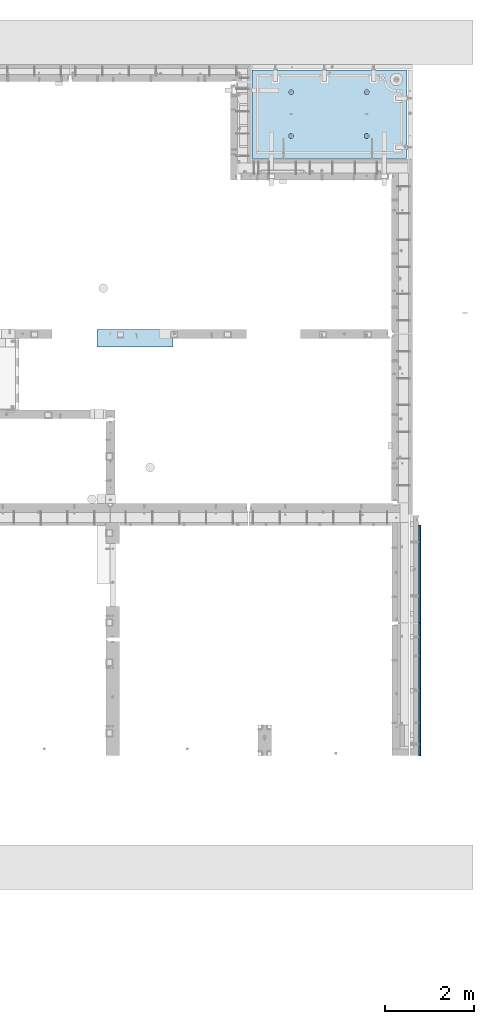
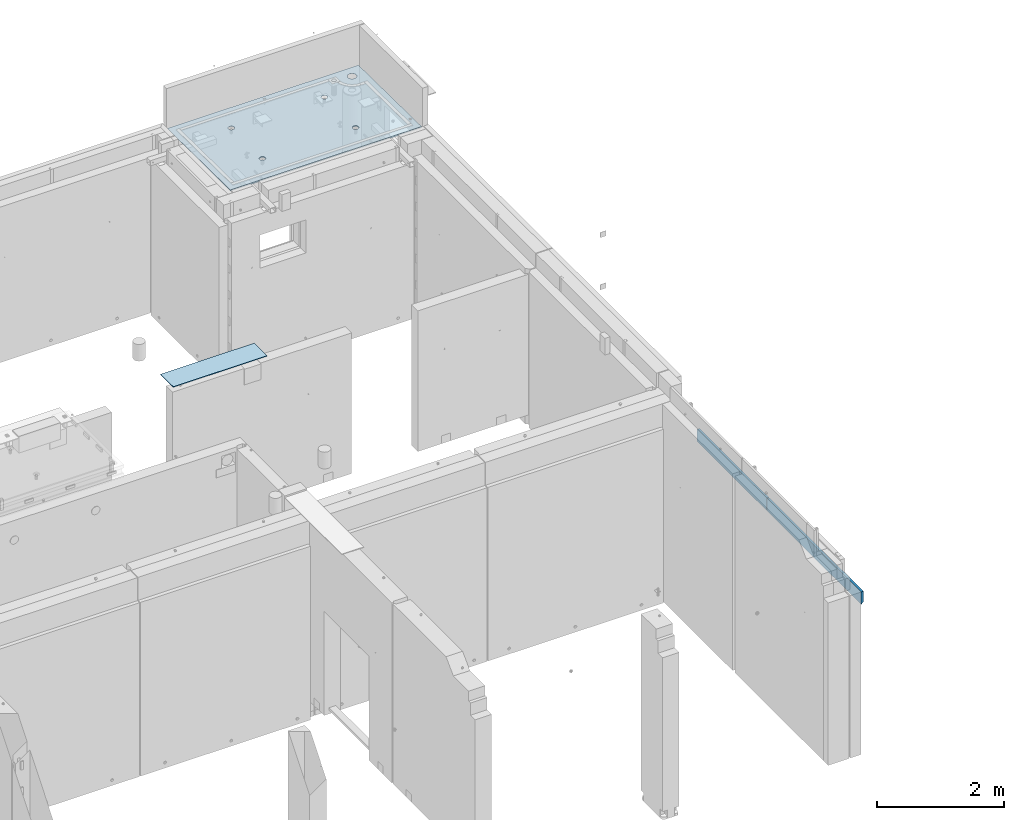
# One storey, part 151 of 264: 3 slabs, 1 plate, 4 elements without a shape of their own.
"""IFC2X3 building model written with IfcOpenShell, lengths in millimetres."""

from ifc_helpers import new_model, si_unit, frame, origin_with_axes, place, context, subcontext, project, spatial, faceted_brep, material, type_object, element, aggregate, save


model = new_model("IFC2X3")

# Units and contexts
model_context = context("Model", 3, precision=1e-05, world=origin_with_axes())
body_context = subcontext(model_context, "Body", "Model", "MODEL_VIEW")
ifc_project = project(units=[si_unit("LENGTHUNIT", "METRE", prefix="MILLI"), si_unit("AREAUNIT", "SQUARE_METRE"), si_unit("VOLUMEUNIT", "CUBIC_METRE"), si_unit("MASSUNIT", "GRAM", prefix="KILO"), si_unit("TIMEUNIT", "SECOND"), si_unit("PLANEANGLEUNIT", "RADIAN"), si_unit("SOLIDANGLEUNIT", "STERADIAN"), si_unit("THERMODYNAMICTEMPERATUREUNIT", "DEGREE_CELSIUS"), si_unit("LUMINOUSINTENSITYUNIT", "LUMEN")], contexts=[model_context])

# Site, building, storey
site_placement = place(None, origin_with_axes())
site = spatial("IfcSite", under=ifc_project, at=site_placement, CompositionType="ELEMENT")
building_placement = place(site_placement, origin_with_axes())
building = spatial("IfcBuilding", under=site, at=building_placement, CompositionType="ELEMENT")
storey_placement = place(building_placement, origin_with_axes())
storey = spatial("IfcBuildingStorey", under=building, at=storey_placement, Name="K", CompositionType="ELEMENT", Elevation=0.0)

# Assembly, slab
assembly_1_placement = place(storey_placement, origin_with_axes())
assembly_1 = element("IfcElementAssembly", 1, at=assembly_1_placement, inside=storey, AssemblyPlace="NOTDEFINED", PredefinedType="REINFORCEMENT_UNIT")
ifc_material_1 = material(Name="CONCRETE/C35/45")
slab_type_1 = type_object("IfcSlabType", PredefinedType="NOTDEFINED")
slab_1_placement = place(assembly_1_placement, frame((31779.9998568133, 20899.9965573523, 81717.5), z_axis=(0.0, 1.0, 0.0), x_axis=(1.0, 0.0, 0.0)))
slab_1 = element("IfcSlab", 2, at=slab_1_placement, type_object=slab_type_1, material=ifc_material_1, PredefinedType="FLOOR", context=body_context, shape_type="Brep", body=[
    faceted_brep([(3302.44337536279, 9.54777926253155, 1750.59690310309), (3302.44337536279, 12.4999999999563, 1750.59690310309), (3294.95084367494, 12.4999999999563, 1732.50833148578), (3294.95084367494, 9.31996391940629, 1732.50833148578), (3283.0319469801, 12.4999999999563, 1716.97532289679), (3283.0319469801, 9.12433444922499, 1716.97532289679), (3267.49893839111, 12.4999999999563, 1705.05642620194), (3267.49893839111, 8.97422267710499, 1705.05642620194), (3249.41036677379, 12.4999999999563, 1697.5638945141), (3249.41036677379, 8.87985847225355, 1697.5638945141), (3229.99893839111, 12.4999999999563, 1695.00833148578), (3229.99893839111, 8.84767259929504, 1695.00833148578), (3210.58751000842, 12.4999999999563, 1697.5638945141), (3210.58751000842, 8.87985847225355, 1697.5638945141), (3192.49893839111, 12.4999999999563, 1705.05642620194), (3192.49893839111, 8.97422267710499, 1705.05642620194), (3176.96592980211, 12.4999999999563, 1716.97532289679), (3176.96592980211, 9.12433444922499, 1716.97532289679), (3165.04703310728, 12.4999999999563, 1732.50833148578), (3165.04703310728, 9.31996391940629, 1732.50833148578), (3157.55450141943, 12.4999999999563, 1750.59690310309), (3157.55450141943, 9.5477792625461, 1750.59690310309), (3154.99893839111, 12.4999999999563, 1770.00833148578), (3154.99893839111, 9.79225523950299, 1770.00833148578), (3157.55450141943, 12.4999999999563, 1789.41975986847), (3157.55450141943, 10.0367312164744, 1789.41975986847), (3165.04703310728, 12.4999999999563, 1807.50833148578), (3165.04703310728, 10.2645465596142, 1807.50833148578), (3176.96592980211, 12.4999999999563, 1823.04134007477), (3176.96592980211, 10.4601760297955, 1823.04134007477), (3192.49893839111, 12.4999999999563, 1834.96023676961), (3192.49893839111, 10.610287801901, 1834.96023676961), (3210.58751000842, 12.4999999999563, 1842.45276845746), (3210.58751000842, 10.704652006767, 1842.45276845746), (3229.99893839111, 12.4999999999563, 1845.00833148578), (3229.99893839111, 10.7368378797255, 1845.00833148578), (3249.41036677379, 12.4999999999563, 1842.45276845746), (3249.41036677379, 10.704652006767, 1842.45276845746), (3267.49893839111, 12.4999999999563, 1834.96023676961), (3267.49893839111, 10.610287801901, 1834.96023676961), (3283.0319469801, 12.4999999999563, 1823.04134007477), (3283.0319469801, 10.4601760297955, 1823.04134007477), (3294.95084367494, 12.4999999999563, 1807.50833148578), (3294.95084367494, 10.2645465596142, 1807.50833148578), (3302.44337536279, 12.4999999999563, 1789.41975986847), (3302.44337536279, 10.0367312164744, 1789.41975986847), (3304.99893839111, 12.4999999999563, 1770.00833148578), (3304.99893839111, 9.79225523950299, 1770.00833148578), (7.41420080885291e-08, 12.4999999999927, 0.0), (-7.41420080885291e-08, -12.5, -3.63797880709171e-12), (0.0, 12.5, 1985.00366210938), (3470.0, 12.5, 0.0), (3470.00000000004, 12.4999999999563, 1985.00366210935), (3470.0, -12.5, 0.0), (2614.71871715545, -5.93617388149141, 521.168755308547), (2613.67503600632, 12.4999999999709, 520.829642746605), (2616.18047624359, 12.4999999999709, 505.010915653602), (2617.28998057371, -6.13967274603783, 505.010915653602), (2607.28293696061, -5.7526757610467, 535.738532951145), (2606.40396524136, 12.4999999999709, 535.099922616191), (2595.7125242481, -5.60710538028798, 547.296842506817), (2595.0790070157, 12.4999999999709, 546.424880841845), (2581.14006820649, -5.51366887726181, 554.715714533479), (2580.80872714612, 12.4999999999709, 553.695951606805), (2564.99000005311, -5.48147745869937, 557.271717883286), (2564.99000005311, 12.4999999999709, 556.201391844079), (2548.83993189974, -5.51366887726181, 554.715714533479), (2549.17127296011, 12.4999999999709, 553.695951606805), (2534.26747585813, -5.60710538028798, 547.296842506817), (2534.90099309052, 12.4999999999709, 546.424880841845), (2522.69706314561, -5.75267576103215, 535.738532951145), (2523.57603486487, 12.4999999999709, 535.099922616191), (2515.26128295077, -5.93617388147686, 521.168755308547), (2516.30496409991, 12.4999999999709, 520.829642746605), (2512.69001953251, -6.13967274603783, 505.010915653602), (2513.79952386263, 12.4999999999709, 505.010915653602), (2515.23823726424, -6.34326591769059, 488.84558800119), (2516.30496409991, 12.4999999999709, 489.192188560599), (2522.65977443627, -6.52701093736687, 474.256206522903), (2523.57603486487, 12.4999999999709, 474.921908691009), (2534.2301871423, -6.67288650246337, 462.673665286093), (2534.90099309052, 12.4999999999709, 463.596950465359), (2548.81688620273, -6.76656990486663, 455.235189411429), (2549.17127296011, 12.4999999999709, 456.325879700398), (2564.99000005311, -6.79885563062271, 452.67169805654), (2564.99000005311, 12.4999999999709, 453.820439463125), (2581.16311390349, -6.76656990486663, 455.235189411429), (2580.80872714612, 12.4999999999709, 456.325879700398), (2595.74981296392, -6.67288650246337, 462.673665286093), (2595.07900701571, 12.4999999999709, 463.596950465359), (2607.32022566996, -6.52701093736687, 474.256206522903), (2606.40396524136, 12.4999999999709, 474.921908691009), (2614.74176284199, -6.34326591769059, 488.84558800119), (2613.67503600632, 12.4999999999709, 489.192188560599), (924.718717121814, -5.93617388307757, 521.168755181017), (923.675035972585, 12.4999999999854, 520.829642619046), (926.180476209858, 12.4999999999854, 505.010915526043), (927.289980540074, -6.13967274762399, 505.010915526043), (917.282936926953, -5.75267576263286, 535.738532823641), (916.403965207624, 12.4999999999854, 535.099922488633), (905.712524214421, -5.60710538187413, 547.296842379335), (905.07900698197, 12.4999999999854, 546.424880714287), (891.140068172776, -5.51366887886252, 554.715714406011), (890.808727112384, 12.4999999999854, 553.695951479247), (874.990000019381, -5.48147746030008, 557.271717755822), (874.990000019381, 12.4999999999854, 556.20139171652), (858.839931865987, -5.51366887886252, 554.715714406011), (859.171272926378, 12.4999999999854, 553.695951479247), (844.267475824341, -5.60710538187413, 547.296842379335), (844.900993056792, 12.4999999999854, 546.424880714287), (832.697063111809, -5.75267576263286, 535.738532823641), (833.576034831138, 12.4999999999854, 535.099922488633), (825.261282916948, -5.93617388307757, 521.168755181017), (826.304964066177, 12.4999999999854, 520.829642619046), (822.690019498688, -6.13967274762399, 505.010915526043), (823.799523828904, 12.4999999999854, 505.010915526043), (825.238237230413, -6.34326591927675, 488.845587873602), (826.304964066174, 12.4999999999854, 489.19218843304), (832.659774402466, -6.52701093895303, 474.25620639529), (833.576034831141, 12.4999999999854, 474.921908563454), (844.230187108518, -6.67288650404953, 462.673665158458), (844.900993056788, 12.4999999999854, 463.5969503378), (858.816886168974, -6.76656990646734, 455.23518928378), (859.171272926378, 12.4999999999854, 456.32587957284), (874.990000019381, -6.79885563222342, 452.671697928887), (874.990000019381, 12.4999999999854, 453.820439335566), (891.163113869789, -6.76656990646734, 455.23518928378), (890.808727112384, 12.4999999999854, 456.32587957284), (905.749812930244, -6.67288650404953, 462.673665158458), (905.079006981974, 12.4999999999854, 463.5969503378), (917.320225636297, -6.52701093895303, 474.25620639529), (916.403965207621, 12.4999999999854, 474.921908563454), (924.741762808349, -6.34326591927675, 488.845587873602), (923.675035972588, 12.4999999999854, 489.19218843304), (924.02016693788, 6.4034111394576, 1500.93361352766), (923.67503595199, 12.4999999999854, 1500.82147367257), (926.18047618926, 12.4999999999854, 1485.00274657956), (926.555311256641, 6.20277086795249, 1485.00274657956), (916.688838773403, 6.58433162167785, 1515.29872631776), (916.403965187026, 12.4999999999854, 1515.09175354215), (905.280958178348, 6.7278571434581, 1526.69467377167), (905.079006961372, 12.4999999999854, 1526.4167117678), (890.913204613287, 6.81998112349538, 1534.0093312807), (890.808727091786, 12.4999999999854, 1533.68778253277), (874.989999998783, 6.85172034216521, 1536.52942989253), (874.989999998783, 12.4999999999854, 1536.19322277004), (859.066795384279, 6.81998112349538, 1534.0093312807), (859.17127290578, 12.4999999999854, 1533.68778253277), (844.699041819218, 6.7278571434581, 1526.69467377167), (844.900993036194, 12.4999999999854, 1526.4167117678), (833.291161224162, 6.58433162167785, 1515.29872631776), (833.57603481054, 12.4999999999854, 1515.09175354215), (825.959833059685, 6.4034111394576, 1500.93361352766), (826.304964045576, 12.4999999999854, 1500.82147367257), (823.424688740924, 6.20277086795249, 1485.00274657956), (823.799523808306, 12.4999999999854, 1485.00274657956), (825.93711110095, 6.00203761411831, 1469.06449681953), (826.304964045576, 12.4999999999854, 1469.18401948656), (833.254396317472, 5.82087370089721, 1454.68005557312), (833.57603481054, 12.4999999999854, 1454.91373961698), (844.66227690614, 5.67704728177341, 1443.26021682579), (844.90099303619, 12.4999999999854, 1443.58878139132), (859.044073415214, 5.58467987058975, 1435.9262308483), (859.17127290578, 12.4999999999854, 1436.31771062636), (874.989999998783, 5.55284766948898, 1433.39874941703), (874.989999998783, 12.4999999999854, 1433.81227038909), (890.935926582351, 5.58467987058975, 1435.9262308483), (890.808727091786, 12.4999999999854, 1436.31771062636), (905.317723091426, 5.67704728177341, 1443.26021682579), (905.079006961376, 12.4999999999854, 1443.58878139132), (916.725603680094, 5.82087370089721, 1454.68005557312), (916.403965187026, 12.4999999999854, 1454.91373961698), (924.042888896616, 6.00203761411831, 1469.06449681953), (923.67503595199, 12.4999999999854, 1469.18401948656), (2564.9899999698, 12.4999999999709, 1433.81227048016), (2564.9899999698, 5.55284767062403, 1433.39874950818), (2580.93592655335, 5.5846798717248, 1435.92623093945), (2580.8087270628, 12.4999999999709, 1436.31771071744), (2549.17127287679, 12.4999999999709, 1436.31771071744), (2549.04407338624, 5.5846798717248, 1435.92623093945), (2534.9009930072, 12.4999999999709, 1443.5887814824), (2534.66227687719, 5.67704728290846, 1443.26021691693), (2523.57603478155, 12.4999999999709, 1454.91373970805), (2523.25439628854, 5.82087370203226, 1454.68005566423), (2516.30496401659, 12.4999999999709, 1469.18401957764), (2515.93711107203, 6.00203761523881, 1469.06449691063), (2513.79952377931, 12.4999999999709, 1485.00274667064), (2513.424688712, 6.20277086908754, 1485.00274667064), (2516.30496401659, 12.4999999999709, 1500.82147376364), (2515.95983303076, 6.40341114059265, 1500.93361361872), (2523.57603478155, 12.4999999999709, 1515.09175363323), (2523.29116119523, 6.5843316228129, 1515.2987264088), (2534.90099300721, 12.4999999999709, 1526.41671185888), (2534.69904179027, 6.72785714459314, 1526.69467386269), (2549.17127287679, 12.4999999999709, 1533.68778262385), (2549.06679535531, 6.81998112463043, 1534.00933137171), (2564.9899999698, 12.4999999999709, 1536.19322286112), (2564.9899999698, 6.85172034330026, 1536.52942998354), (2580.8087270628, 12.4999999999709, 1533.68778262385), (2580.91320458428, 6.81998112463043, 1534.00933137171), (2595.07900693238, 12.4999999999709, 1526.41671185888), (2595.28095814932, 6.72785714459314, 1526.69467386269), (2606.40396515804, 12.4999999999709, 1515.09175363323), (2606.68883874436, 6.5843316228129, 1515.2987264088), (2613.675035923, 12.4999999999709, 1500.82147376364), (2614.02016690883, 6.40341114059265, 1500.93361361872), (2606.72560365105, 5.82087370203226, 1454.68005566423), (2595.3177230624, 5.67704728290846, 1443.26021691693), (2616.55531122759, 6.20277086908754, 1485.00274667064), (2614.04288886756, 6.00203761523881, 1469.06449691063), (2595.07900693239, 12.4999999999709, 1443.5887814824), (2606.40396515804, 12.4999999999709, 1454.91373970805), (2613.675035923, 12.4999999999709, 1469.18401957764), (2616.18047616028, 12.4999999999709, 1485.00274667064)], [[[0, 1, 2, 3]], [[3, 2, 4, 5]], [[5, 4, 6, 7]], [[7, 6, 8, 9]], [[9, 8, 10, 11]], [[11, 10, 12, 13]], [[13, 12, 14, 15]], [[15, 14, 16, 17]], [[17, 16, 18, 19]], [[19, 18, 20, 21]], [[21, 20, 22, 23]], [[23, 22, 24, 25]], [[25, 24, 26, 27]], [[27, 26, 28, 29]], [[29, 28, 30, 31]], [[31, 30, 32, 33]], [[33, 32, 34, 35]], [[35, 34, 36, 37]], [[37, 36, 38, 39]], [[39, 38, 40, 41]], [[41, 40, 42, 43]], [[43, 42, 44, 45]], [[45, 44, 46, 47]], [[47, 46, 1, 0]], [[48, 49, 50]], [[51, 52, 53]], [[48, 51, 53, 49]], [[54, 55, 56, 57]], [[58, 59, 55, 54]], [[60, 61, 59, 58]], [[62, 63, 61, 60]], [[64, 65, 63, 62]], [[66, 67, 65, 64]], [[67, 66, 68, 69]], [[69, 68, 70, 71]], [[71, 70, 72, 73]], [[73, 72, 74, 75]], [[75, 74, 76, 77]], [[77, 76, 78, 79]], [[79, 78, 80, 81]], [[81, 80, 82, 83]], [[83, 82, 84, 85]], [[86, 87, 85, 84]], [[88, 89, 87, 86]], [[90, 91, 89, 88]], [[92, 93, 91, 90]], [[57, 56, 93, 92]], [[94, 95, 96, 97]], [[98, 99, 95, 94]], [[100, 101, 99, 98]], [[102, 103, 101, 100]], [[104, 105, 103, 102]], [[106, 107, 105, 104]], [[107, 106, 108, 109]], [[109, 108, 110, 111]], [[111, 110, 112, 113]], [[113, 112, 114, 115]], [[115, 114, 116, 117]], [[117, 116, 118, 119]], [[119, 118, 120, 121]], [[121, 120, 122, 123]], [[123, 122, 124, 125]], [[126, 127, 125, 124]], [[128, 129, 127, 126]], [[130, 131, 129, 128]], [[132, 133, 131, 130]], [[97, 96, 133, 132]], [[134, 135, 136, 137]], [[138, 139, 135, 134]], [[140, 141, 139, 138]], [[142, 143, 141, 140]], [[144, 145, 143, 142]], [[146, 147, 145, 144]], [[148, 149, 147, 146]], [[150, 151, 149, 148]], [[151, 150, 152, 153]], [[153, 152, 154, 155]], [[155, 154, 156, 157]], [[157, 156, 158, 159]], [[159, 158, 160, 161]], [[161, 160, 162, 163]], [[163, 162, 164, 165]], [[165, 164, 166, 167]], [[167, 166, 168, 169]], [[170, 171, 169, 168]], [[172, 173, 171, 170]], [[137, 136, 173, 172]], [[174, 175, 176, 177]], [[178, 179, 175, 174]], [[180, 181, 179, 178]], [[182, 183, 181, 180]], [[184, 185, 183, 182]], [[186, 187, 185, 184]], [[188, 189, 187, 186]], [[190, 191, 189, 188]], [[191, 190, 192, 193]], [[193, 192, 194, 195]], [[195, 194, 196, 197]], [[197, 196, 198, 199]], [[199, 198, 200, 201]], [[201, 200, 202, 203]], [[203, 202, 204, 205]], [[52, 50, 49, 53], [3, 5, 7, 9, 11, 13, 15, 17, 19, 21, 23, 25, 27, 29, 31, 33, 35, 37, 39, 41, 43, 45, 47, 0], [206, 207, 176, 175, 179, 181, 183, 185, 187, 189, 191, 193, 195, 197, 199, 201, 203, 205, 208, 209], [170, 168, 166, 164, 162, 160, 158, 156, 154, 152, 150, 148, 146, 144, 142, 140, 138, 134, 137, 172], [130, 128, 126, 124, 122, 120, 118, 116, 114, 112, 110, 108, 106, 104, 102, 100, 98, 94, 97, 132], [90, 88, 86, 84, 82, 80, 78, 76, 74, 72, 70, 68, 66, 64, 62, 60, 58, 54, 57, 92]], [[177, 176, 207, 210]], [[206, 211, 210, 207]], [[209, 212, 211, 206]], [[208, 213, 212, 209]], [[205, 204, 213, 208]], [[51, 48, 50, 52], [42, 40, 38, 36, 34, 32, 30, 28, 26, 24, 22, 20, 18, 16, 14, 12, 10, 8, 6, 4, 2, 1, 46, 44], [202, 200, 198, 196, 194, 192, 190, 188, 186, 184, 182, 180, 178, 174, 177, 210, 211, 212, 213, 204], [139, 141, 143, 145, 147, 149, 151, 153, 155, 157, 159, 161, 163, 165, 167, 169, 171, 173, 136, 135], [99, 101, 103, 105, 107, 109, 111, 113, 115, 117, 119, 121, 123, 125, 127, 129, 131, 133, 96, 95], [59, 61, 63, 65, 67, 69, 71, 73, 75, 77, 79, 81, 83, 85, 87, 89, 91, 93, 56, 55]]]),
])
aggregate(assembly_1, [slab_1])

assembly_2_placement = place(storey_placement, origin_with_axes())
assembly_2 = element("IfcElementAssembly", 3, at=assembly_2_placement, inside=storey, AssemblyPlace="NOTDEFINED", PredefinedType="REINFORCEMENT_UNIT")
slab_type_2 = type_object("IfcSlabType", PredefinedType="NOTDEFINED")
slab_2_placement = place(assembly_2_placement, frame((35510.0000014901, 9022.49965490547, 80815.0030770672), z_axis=(0.0, 0.0, -1.0), x_axis=(1.0, 0.0, 0.0)))
slab_2 = element("IfcSlab", 4, at=slab_2_placement, type_object=slab_type_2, material=ifc_material_1, PredefinedType="FLOOR", context=body_context, shape_type="Brep", body=[
    faceted_brep([(0.0, -1477.5, 0.0), (0.0, -1477.5, 240.0), (0.0, 1477.5, 240.0), (0.0, 1477.5, 0.0), (40.0, -1477.5, 200.0), (40.0, 1477.5, 200.0), (40.0, -1477.5, 0.0), (40.0, 1477.5, 0.0)], [[[0, 1, 2, 3]], [[1, 4, 5, 2]], [[4, 6, 7, 5]], [[6, 0, 3, 7]], [[5, 7, 3, 2]], [[6, 4, 1, 0]]]),
])
aggregate(assembly_2, [slab_2])

assembly_3_placement = place(storey_placement, origin_with_axes())
assembly_3 = element("IfcElementAssembly", 5, at=assembly_3_placement, inside=storey, AssemblyPlace="NOTDEFINED", PredefinedType="REINFORCEMENT_UNIT")
slab_type_3 = type_object("IfcSlabType", PredefinedType="NOTDEFINED")
slab_3_placement = place(assembly_3_placement, frame((35510.0000014901, 11604.9896549055, 80815.0030770672), z_axis=(0.0, 0.0, -1.0), x_axis=(1.0, 0.0, 0.0)))
slab_3 = element("IfcSlab", 6, at=slab_3_placement, type_object=slab_type_3, material=ifc_material_1, PredefinedType="FLOOR", context=body_context, shape_type="Brep", body=[
    faceted_brep([(0.0, -1090.0, 0.0), (0.0, -1090.0, 240.0), (0.0, 1090.0, 240.0), (0.0, 1090.0, 0.0), (40.0, -1090.0, 200.0), (40.0, 1090.0, 200.0), (40.0, -1090.0, 0.0), (40.0, 1090.0, 0.0)], [[[0, 1, 2, 3]], [[1, 4, 5, 2]], [[4, 6, 7, 5]], [[6, 0, 3, 7]], [[5, 7, 3, 2]], [[6, 4, 1, 0]]]),
])
aggregate(assembly_3, [slab_3])

# Assembly, plate
assembly_4_placement = place(storey_placement, origin_with_axes())
assembly_4 = element("IfcElementAssembly", 7, at=assembly_4_placement, inside=storey, Name="Steel Assembly", AssemblyPlace="NOTDEFINED", PredefinedType="NOTDEFINED")
ifc_material_2 = material()
plate_type = type_object("IfcPlateType", PredefinedType="NOTDEFINED")
plate_placement = place(assembly_4_placement, frame((28309.9999105288, 16680.0000293051, 81725.6000003815), z_axis=(0.0, 1.0, 0.0), x_axis=(1.0, 0.0, 0.0)))
plate = element("IfcPlate", 8, at=plate_placement, type_object=plate_type, material=ifc_material_2, Name="YP", context=body_context, shape_type="Brep", body=[
    faceted_brep([(0.0, -5.0, 0.0), (0.0, -5.0, 399.999633789063), (0.0, 5.0, 399.999633789063), (0.0, 5.0, 0.0), (1700.00073242188, -5.0, 399.999633789063), (1700.00073242188, 5.0, 399.999633789063), (1700.00073242188, -5.0, 0.0), (1700.00073242188, 5.0, 0.0)], [[[0, 1, 2, 3]], [[1, 4, 5, 2]], [[4, 6, 7, 5]], [[6, 0, 3, 7]], [[5, 7, 3, 2]], [[6, 4, 1, 0]]]),
])
aggregate(assembly_4, [plate])

save(model, "model.ifc")
